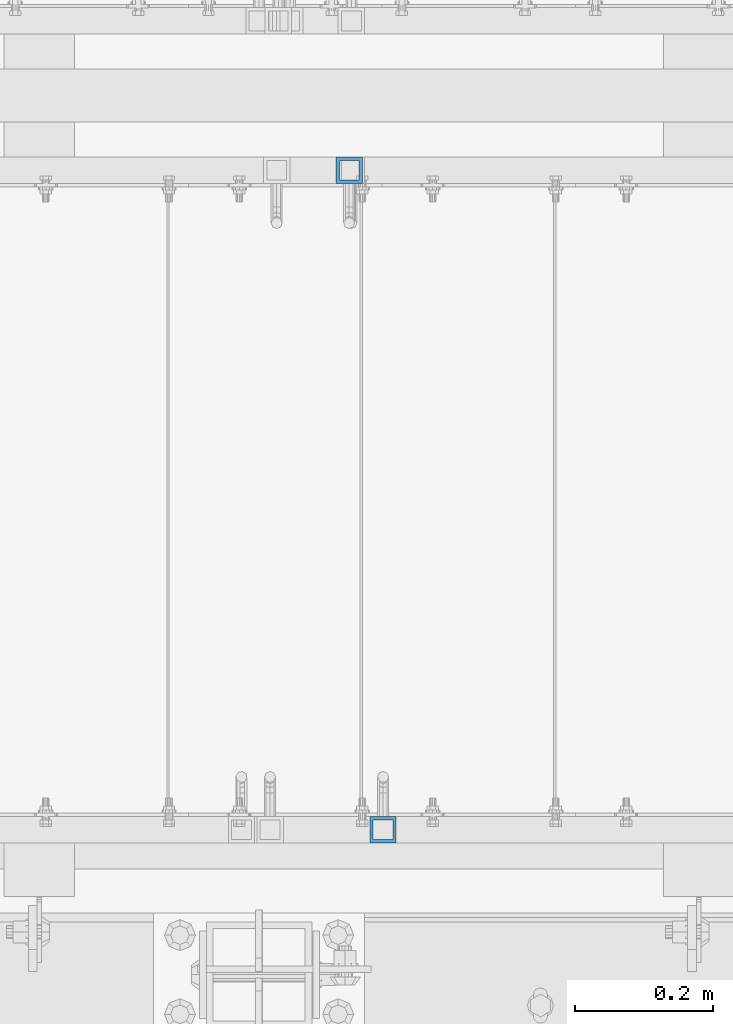
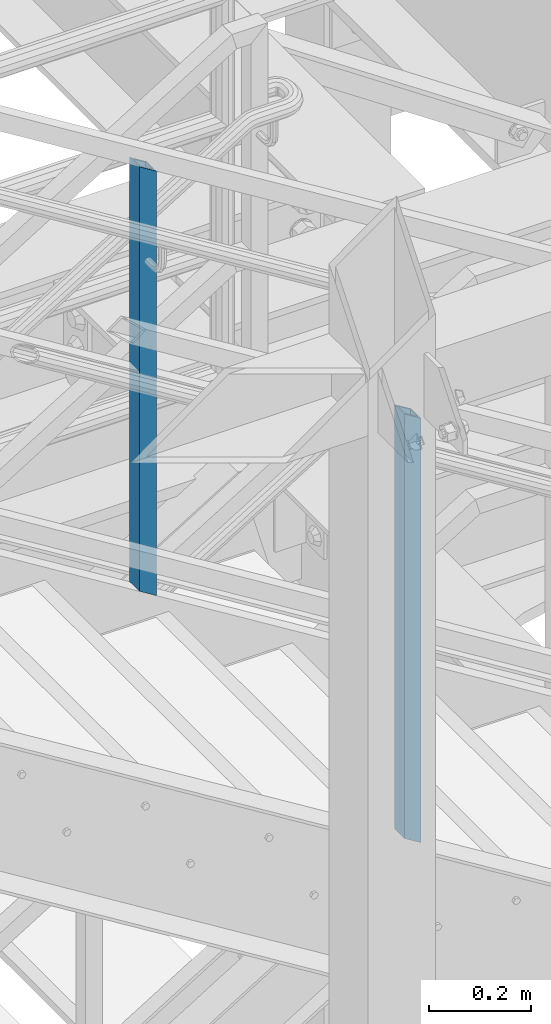
# One storey, part 583 of 1876: 2 columns, 2 elements without a shape of their own.
"""IFC2X3 building model written with IfcOpenShell, lengths in millimetres."""

from ifc_helpers import new_model, si_unit, frame, origin_with_axes, place, context, subcontext, project, spatial, faceted_brep, material, type_object, element, aggregate, save


model = new_model("IFC2X3")

# Units and contexts
model_context = context("Model", 3, precision=1e-05, world=origin_with_axes())
body_context = subcontext(model_context, "Body", "Model", "MODEL_VIEW")
ifc_project = project(units=[si_unit("LENGTHUNIT", "METRE", prefix="MILLI"), si_unit("AREAUNIT", "SQUARE_METRE"), si_unit("VOLUMEUNIT", "CUBIC_METRE"), si_unit("MASSUNIT", "GRAM", prefix="KILO"), si_unit("TIMEUNIT", "SECOND"), si_unit("PLANEANGLEUNIT", "RADIAN"), si_unit("SOLIDANGLEUNIT", "STERADIAN"), si_unit("THERMODYNAMICTEMPERATUREUNIT", "DEGREE_CELSIUS"), si_unit("LUMINOUSINTENSITYUNIT", "LUMEN")], contexts=[model_context])

# Site, building, storey
site_placement = place(None, origin_with_axes())
site = spatial("IfcSite", under=ifc_project, at=site_placement, CompositionType="ELEMENT")
building_placement = place(site_placement, origin_with_axes())
building = spatial("IfcBuilding", under=site, at=building_placement, Name="Undefined", CompositionType="ELEMENT")
storey_placement = place(building_placement, origin_with_axes())
storey = spatial("IfcBuildingStorey", under=building, at=storey_placement, Name="Undefined", CompositionType="ELEMENT", Elevation=0.0)

# Assembly, column
assembly_1_placement = place(storey_placement, origin_with_axes())
assembly_1 = element("IfcElementAssembly", 1, at=assembly_1_placement, inside=storey, Name="RAIL", AssemblyPlace="NOTDEFINED", PredefinedType="RIGID_FRAME")
ifc_material = material()
column_type = type_object("IfcColumnType", Name="HSS1-1/2X1-1/2X3/16", PredefinedType="NOTDEFINED")
column_1_placement = place(assembly_1_placement, frame((5259.07000023952, -6902.45000114325, 14040.6021072773), z_axis=(1.0, 0.0, 0.0), x_axis=(0.0, 0.0, 1.0)))
column_1 = element("IfcColumn", 2, at=column_1_placement, type_object=column_type, material=ifc_material, Name="POST", ObjectType="HSS1-1/2X1-1/2X3/16", context=body_context, shape_type="Brep", body=[
    faceted_brep([(1026.31295131947, -19.0499999945778, -19.0499992349996), (1026.31295131947, 19.0499992349996, -19.0499992349996), (1002.70890059182, 19.0499992349996, 19.0499992349996), (1002.70890059182, -19.0499992349996, 19.0499992349996), (1023.36244497843, -14.2874994260001, -14.2874994260001), (1005.65940693302, -14.2874994260001, 14.2874994260001), (1005.65940693302, 14.2874994260001, 14.2874994260001), (1023.36244497843, 14.2874994260001, -14.2874994260001), (-11.8020253644645, 19.0499992349996, 19.0499992350001), (-11.8020253644645, -19.0499992349996, 19.0499992350001), (11.8020253632003, -19.0499992349996, -19.0499992350001), (11.8020253632003, 19.0499992349996, -19.0499992350001), (-8.85151902335201, 14.2874994260001, 14.2874994260001), (-8.85151902335201, -14.2874994260001, 14.2874994260001), (8.85151902208599, -14.2874994260001, -14.2874994260001), (8.85151902208599, 14.2874994260001, -14.2874994260001)], [[[0, 1, 2, 3], [4, 5, 6, 7]], [[8, 9, 3, 2]], [[9, 10, 0, 3]], [[10, 11, 1, 0]], [[11, 8, 2, 1]], [[10, 9, 8, 11], [12, 13, 14, 15]], [[15, 14, 4, 7]], [[12, 15, 7, 6]], [[13, 12, 6, 5]], [[14, 13, 5, 4]]]),
])
aggregate(assembly_1, [column_1])

assembly_2_placement = place(storey_placement, origin_with_axes())
assembly_2 = element("IfcElementAssembly", 3, at=assembly_2_placement, inside=storey, Name="RAIL", AssemblyPlace="NOTDEFINED", PredefinedType="RIGID_FRAME")
column_2_placement = place(assembly_2_placement, frame((5210.17500029906, -5949.95000114554, 14070.8939735592), z_axis=(1.0, 0.0, 0.0), x_axis=(0.0, 0.0, 1.0)))
column_2 = element("IfcColumn", 4, at=column_2_placement, type_object=column_type, material=ifc_material, Name="POST", ObjectType="HSS1-1/2X1-1/2X3/16", context=body_context, shape_type="Brep", body=[
    faceted_brep([(1026.31295131947, -19.0499999945778, -19.0499992349996), (1026.31295131947, 19.0499992349996, -19.0499992349996), (1002.70890059182, 19.0499992349996, 19.0499992349996), (1002.70890059182, -19.0499992349996, 19.0499992349996), (1023.36244497843, -14.2874994260001, -14.2874994260001), (1005.65940693302, -14.2874994260001, 14.2874994260001), (1005.65940693302, 14.2874994260001, 14.2874994260001), (1023.36244497843, 14.2874994260001, -14.2874994260001), (-11.8020253644645, 19.0499992349996, 19.0499992350001), (-11.8020253644645, -19.0499992349996, 19.0499992350001), (11.8020253632003, -19.0499992349996, -19.0499992350001), (11.8020253632003, 19.0499992349996, -19.0499992350001), (-8.85151902335201, 14.2874994260001, 14.2874994260001), (-8.85151902335201, -14.2874994260001, 14.2874994260001), (8.85151902208599, -14.2874994260001, -14.2874994260001), (8.85151902208599, 14.2874994260001, -14.2874994260001)], [[[0, 1, 2, 3], [4, 5, 6, 7]], [[8, 9, 3, 2]], [[9, 10, 0, 3]], [[10, 11, 1, 0]], [[11, 8, 2, 1]], [[10, 9, 8, 11], [12, 13, 14, 15]], [[15, 14, 4, 7]], [[12, 15, 7, 6]], [[13, 12, 6, 5]], [[14, 13, 5, 4]]]),
])
aggregate(assembly_2, [column_2])

save(model, "model.ifc")
